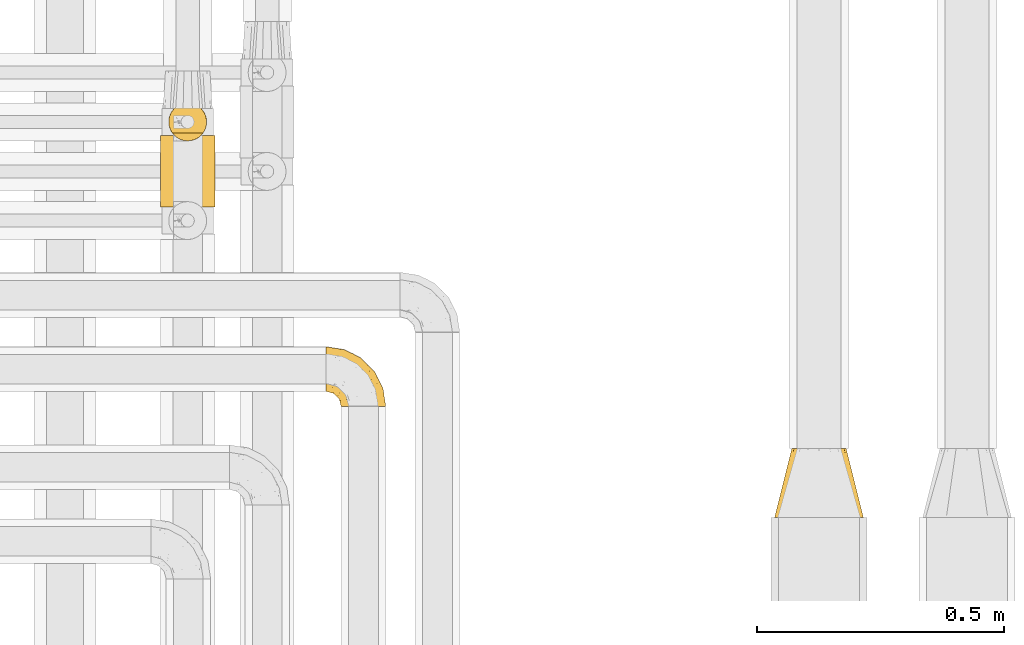
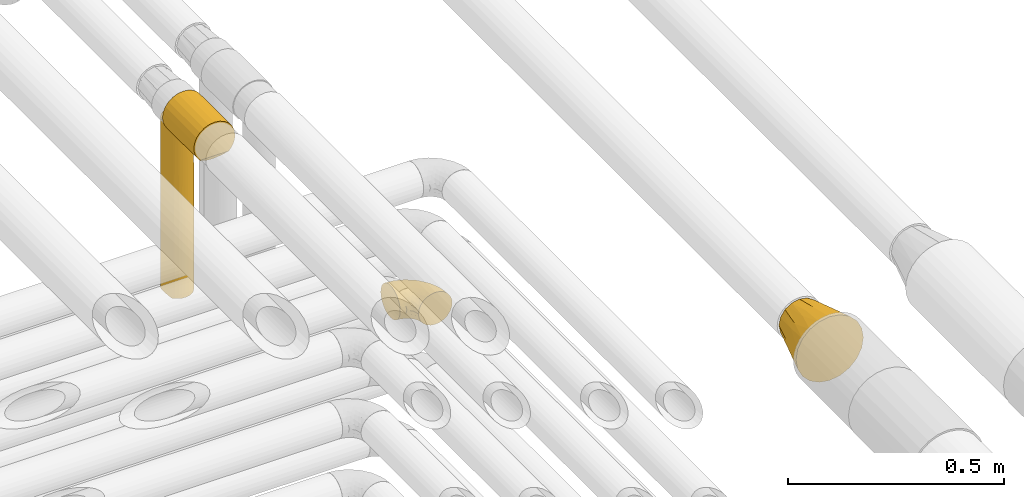
# One storey, part 342 of 827: 4 coverings.
"""IFC2X3 building model written with IfcOpenShell, lengths in millimetres."""

from ifc_helpers import new_model, entity, si_unit, converted_unit, derived_unit, direction, frame, origin, place, context, subcontext, project, spatial, faceted_brep, element, save


model = new_model("IFC2X3")

# Units and contexts
model_context = context("Model", 3, precision=0.01, world=origin(), true_north=direction((6.12303176911189e-17, 1.0)))
body_context = subcontext(model_context, "Body", "Model", "MODEL_VIEW")
ifc_project = project(units=[si_unit("LENGTHUNIT", "METRE", prefix="MILLI"), si_unit("AREAUNIT", "SQUARE_METRE"), si_unit("VOLUMEUNIT", "CUBIC_METRE"), converted_unit("PLANEANGLEUNIT", "DEGREE", entity("IfcRatioMeasure", 0.0174532925199433), si_unit("PLANEANGLEUNIT", "RADIAN"), dimensions=[0, 0, 0, 0, 0, 0, 0]), si_unit("MASSUNIT", "GRAM", prefix="KILO"), derived_unit("MASSDENSITYUNIT", [(si_unit("MASSUNIT", "GRAM", prefix="KILO"), 1), (si_unit("LENGTHUNIT", "METRE"), -3)]), derived_unit("MOMENTOFINERTIAUNIT", [(si_unit("LENGTHUNIT", "METRE"), 4)]), si_unit("TIMEUNIT", "SECOND"), si_unit("FREQUENCYUNIT", "HERTZ"), si_unit("THERMODYNAMICTEMPERATUREUNIT", "DEGREE_CELSIUS"), derived_unit("THERMALTRANSMITTANCEUNIT", [(si_unit("MASSUNIT", "GRAM", prefix="KILO"), 1), (si_unit("THERMODYNAMICTEMPERATUREUNIT", "KELVIN"), -1), (si_unit("TIMEUNIT", "SECOND"), -3)]), derived_unit("VOLUMETRICFLOWRATEUNIT", [(si_unit("LENGTHUNIT", "METRE"), 3), (si_unit("TIMEUNIT", "SECOND"), -1)]), derived_unit("MASSFLOWRATEUNIT", [(si_unit("MASSUNIT", "GRAM", prefix="KILO"), 1), (si_unit("TIMEUNIT", "SECOND"), -1)]), derived_unit("ROTATIONALFREQUENCYUNIT", [(si_unit("TIMEUNIT", "SECOND"), -1)]), si_unit("ELECTRICCURRENTUNIT", "AMPERE"), si_unit("ELECTRICVOLTAGEUNIT", "VOLT"), si_unit("POWERUNIT", "WATT"), si_unit("FORCEUNIT", "NEWTON", prefix="KILO"), si_unit("ILLUMINANCEUNIT", "LUX"), si_unit("LUMINOUSFLUXUNIT", "LUMEN"), si_unit("LUMINOUSINTENSITYUNIT", "CANDELA"), derived_unit("USERDEFINED", [(si_unit("MASSUNIT", "GRAM", prefix="KILO"), -1), (si_unit("LENGTHUNIT", "METRE"), -2), (si_unit("TIMEUNIT", "SECOND"), 3), (si_unit("LUMINOUSFLUXUNIT", "LUMEN"), 1)]), derived_unit("LINEARVELOCITYUNIT", [(si_unit("LENGTHUNIT", "METRE"), 1), (si_unit("TIMEUNIT", "SECOND"), -1)]), si_unit("PRESSUREUNIT", "PASCAL"), derived_unit("USERDEFINED", [(si_unit("LENGTHUNIT", "METRE"), -2), (si_unit("MASSUNIT", "GRAM", prefix="KILO"), 1), (si_unit("TIMEUNIT", "SECOND"), -2)]), derived_unit("LINEARFORCEUNIT", [(si_unit("MASSUNIT", "GRAM", prefix="KILO"), 1), (si_unit("LENGTHUNIT", "METRE"), 1), (si_unit("TIMEUNIT", "SECOND"), -2), (si_unit("LENGTHUNIT", "METRE"), -1)]), derived_unit("PLANARFORCEUNIT", [(si_unit("MASSUNIT", "GRAM", prefix="KILO"), 1), (si_unit("LENGTHUNIT", "METRE"), 1), (si_unit("TIMEUNIT", "SECOND"), -2), (si_unit("LENGTHUNIT", "METRE"), -2)])], contexts=[model_context])

# Site, building, storey
site_placement = place(None, origin())
site = spatial("IfcSite", under=ifc_project, at=site_placement, CompositionType="ELEMENT")
building_placement = place(site_placement, origin())
building = spatial("IfcBuilding", under=site, at=building_placement, CompositionType="ELEMENT")
storey_placement = place(building_placement, frame((0.0, 0.0, 28200.0)))
storey = spatial("IfcBuildingStorey", under=building, at=storey_placement, Name="08", CompositionType="ELEMENT", Elevation=28200.0)

# Coverings
covering_1_placement = place(storey_placement, frame((36428.72, 15450.0, 3027.5)))
element("IfcCovering", 1, at=covering_1_placement, inside=storey, Name=":ADSK_", ObjectType=":ADSK_", PredefinedType="INSULATION", context=body_context, shape_type="Brep", body=[
    faceted_brep([(77.54, 31.93, 490.0), (78.4, 40.0, 490.0), (77.09, 49.93, 490.0), (73.25, 59.2, 490.0), (67.15, 67.15, 490.0), (59.2, 73.25, 490.0), (49.93, 77.09, 490.0), (40.0, 78.4, 490.0), (30.06, 77.09, 490.0), (20.8, 73.25, 490.0), (12.84, 67.15, 490.0), (6.74, 59.2, 490.0), (2.9, 49.93, 490.0), (1.6, 40.0, 490.0), (2.45, 31.93, 490.0), (4.98, 24.24, 490.0), (9.06, 17.25, 490.0), (70.93, 17.25, 490.0), (75.01, 24.24, 490.0), (78.4, 40.0, 1.6), (77.09, 30.06, 1.6), (73.25, 20.8, 1.6), (67.15, 12.84, 1.6), (59.2, 6.74, 1.6), (49.93, 2.9, 1.6), (40.0, 1.6, 1.6), (31.79, 2.48, 1.6), (23.98, 5.09, 1.6), (16.91, 9.31, 1.6), (10.9, 14.94, 1.6), (10.9, 65.05, 1.6), (16.91, 70.68, 1.6), (23.98, 74.9, 1.6), (31.79, 77.51, 1.6), (40.0, 78.4, 1.6), (49.93, 77.09, 1.6), (59.2, 73.25, 1.6), (67.15, 67.15, 1.6), (73.25, 59.2, 1.6), (77.09, 49.93, 1.6), (78.4, 40.0, 273.62), (76.48, 28.02, 255.92), (47.46, 2.33, 209.58), (54.76, 4.55, 223.03), (40.0, 1.6, 251.27), (45.97, 2.06, 468.31), (62.33, 8.76, 227.69), (69.27, 15.14, 243.58), (57.33, 5.73, 473.55), (51.79, 3.45, 470.29), (73.48, 21.19, 294.68), (67.02, 12.71, 483.52), (40.0, 1.6, 467.64), (62.45, 8.84, 477.99), (77.65, 47.54, 282.85), (75.47, 54.69, 245.8), (47.38, 77.68, 280.14), (54.69, 75.47, 245.8), (70.46, 63.37, 245.8), (63.37, 70.46, 245.8), (40.0, 78.4, 217.97), (27.82, 76.41, 235.98), (16.62, 70.46, 267.16), (1.6, 40.0, 227.27), (2.97, 50.18, 239.69), (2.2, 46.78, 10.29), (5.35, 56.56, 302.34), (8.89, 62.51, 250.15), (4.0, 53.36, 8.5), (1.6, 40.0, 10.9), (6.92, 59.51, 5.57), (1.6, 40.0, 250.45), (2.2, 33.21, 10.29), (4.0, 26.63, 8.5), (2.97, 29.81, 243.75), (6.92, 20.48, 5.57), (8.88, 17.49, 236.9), (5.36, 23.41, 187.01), (14.98, 10.86, 243.74), (32.49, 2.34, 220.4), (12.97, 12.71, 483.52), (25.25, 4.54, 243.03), (34.02, 2.06, 468.31), (28.2, 3.45, 470.29), (17.54, 8.84, 477.99), (22.66, 5.73, 473.55)], [[[0, 1, 2, 3, 4, 5, 6, 7, 8, 9, 10, 11, 12, 13, 14, 15, 16, 17, 18]], [[19, 20, 21, 22, 23, 24, 25, 26, 27, 28, 29, 30, 31, 32, 33, 34, 35, 36, 37, 38, 39]], [[40, 41, 20]], [[42, 24, 43]], [[42, 25, 24]], [[44, 42, 45]], [[19, 40, 20]], [[46, 43, 23]], [[24, 23, 43]], [[41, 0, 18]], [[22, 21, 47]], [[43, 46, 48]], [[43, 48, 49]], [[49, 45, 42]], [[47, 46, 22]], [[21, 41, 50]], [[51, 47, 17]], [[21, 20, 41]], [[25, 42, 44]], [[40, 1, 0]], [[45, 52, 44]], [[51, 53, 46]], [[47, 50, 17]], [[41, 18, 50]], [[21, 50, 47]], [[17, 50, 18]], [[40, 0, 41]], [[51, 46, 47]], [[42, 43, 49]], [[46, 53, 48]], [[22, 46, 23]], [[54, 39, 55]], [[35, 56, 57]], [[54, 1, 40, 19]], [[55, 39, 38]], [[54, 19, 39]], [[2, 55, 3]], [[55, 2, 54]], [[58, 4, 3]], [[58, 55, 38]], [[59, 58, 37]], [[7, 56, 60]], [[57, 36, 35]], [[35, 34, 60]], [[56, 6, 57]], [[7, 6, 56]], [[59, 5, 4]], [[57, 59, 36]], [[35, 60, 56]], [[57, 5, 59]], [[58, 59, 4]], [[37, 58, 38]], [[5, 57, 6]], [[36, 59, 37]], [[1, 54, 2]], [[55, 58, 3]], [[60, 33, 61]], [[32, 31, 62]], [[62, 61, 32]], [[63, 64, 65]], [[33, 60, 34]], [[61, 33, 32]], [[61, 9, 8]], [[62, 10, 9]], [[12, 11, 66]], [[67, 62, 30]], [[66, 68, 64]], [[67, 10, 62]], [[65, 64, 68]], [[11, 10, 67]], [[65, 69, 63]], [[66, 70, 68]], [[60, 61, 8]], [[66, 11, 67]], [[62, 31, 30]], [[13, 12, 64]], [[64, 63, 71, 13]], [[61, 62, 9]], [[70, 66, 67]], [[70, 67, 30]], [[12, 66, 64]], [[7, 60, 8]], [[72, 73, 74]], [[75, 76, 77]], [[75, 29, 76]], [[78, 76, 29]], [[44, 79, 25]], [[74, 73, 77]], [[14, 71, 74]], [[71, 72, 74]], [[15, 14, 74]], [[15, 77, 76]], [[75, 77, 73]], [[74, 77, 15]], [[15, 76, 16]], [[76, 78, 80]], [[81, 78, 28]], [[44, 52, 82]], [[71, 14, 13]], [[82, 79, 44]], [[81, 26, 79]], [[72, 71, 63, 69]], [[83, 79, 82]], [[83, 81, 79]], [[84, 80, 78]], [[80, 16, 76]], [[83, 85, 81]], [[81, 85, 84]], [[28, 27, 81]], [[81, 84, 78]], [[26, 81, 27]], [[78, 29, 28]], [[25, 79, 26]], [[48, 53, 51, 17, 16, 80, 84, 85, 83, 82, 52, 45, 49]], [[65, 68, 70, 30, 29, 75, 73, 72, 69]]]),
])
covering_2_placement = place(storey_placement, frame((36412.12, 15315.9, 3493.4)))
element("IfcCovering", 2, at=covering_2_placement, inside=storey, Name=":ADSK_", ObjectType=":ADSK_", PredefinedType="INSULATION", context=body_context, shape_type="Brep", body=[
    faceted_brep([(1.6, 1.6, 56.6), (2.68, 1.6, 45.71), (5.89, 1.6, 35.29), (11.1, 1.6, 25.69), (18.1, 1.6, 17.31), (95.09, 1.6, 17.31), (102.09, 1.6, 25.69), (107.3, 1.6, 35.29), (110.51, 1.6, 45.71), (111.6, 1.6, 56.6), (109.72, 1.6, 70.83), (104.23, 1.6, 84.1), (95.49, 1.6, 95.49), (84.1, 1.6, 104.23), (70.83, 1.6, 109.72), (56.6, 1.6, 111.6), (42.36, 1.6, 109.72), (29.1, 1.6, 104.23), (17.7, 1.6, 95.49), (8.96, 1.6, 84.1), (3.47, 1.6, 70.83), (18.1, 146.6, 17.31), (11.1, 146.6, 25.69), (5.89, 146.6, 35.29), (2.68, 146.6, 45.71), (1.6, 146.6, 56.6), (3.47, 146.6, 70.83), (8.96, 146.6, 84.1), (17.7, 146.6, 95.49), (29.1, 146.6, 104.23), (42.36, 146.6, 109.72), (56.6, 146.6, 111.6), (70.83, 146.6, 109.72), (84.1, 146.6, 104.23), (95.49, 146.6, 95.49), (104.23, 146.6, 84.1), (109.72, 146.6, 70.83), (111.6, 146.6, 56.6), (110.51, 146.6, 45.71), (107.3, 146.6, 35.29), (102.09, 146.6, 25.69), (95.09, 146.6, 17.31), (26.39, 141.92, 10.63), (26.39, 6.27, 10.63), (35.81, 138.45, 5.68), (46.0, 136.32, 2.62), (46.0, 11.87, 2.62), (35.81, 9.74, 5.68), (56.6, 135.6, 1.6), (56.6, 12.6, 1.6), (67.19, 136.32, 2.62), (67.19, 11.87, 2.62), (77.38, 138.45, 5.68), (86.8, 141.92, 10.63), (86.8, 6.27, 10.63), (77.38, 9.74, 5.68)], [[[0, 1, 2, 3, 4, 5, 6, 7, 8, 9, 10, 11, 12, 13, 14, 15, 16, 17, 18, 19, 20]], [[21, 22, 23, 24, 25, 26, 27, 28, 29, 30, 31, 32, 33, 34, 35, 36, 37, 38, 39, 40, 41]], [[25, 24, 1, 0]], [[23, 22, 3, 2]], [[24, 23, 2, 1]], [[22, 21, 4, 3]], [[21, 42, 43, 4]], [[44, 45, 46, 47]], [[42, 44, 47, 43]], [[45, 48, 49, 46]], [[48, 50, 51, 49]], [[52, 53, 54, 55]], [[50, 52, 55, 51]], [[5, 54, 53, 41]], [[7, 6, 40, 39]], [[8, 7, 39, 38]], [[9, 8, 38, 37]], [[41, 40, 6, 5]], [[10, 9, 37, 36]], [[11, 10, 36, 35]], [[35, 34, 12, 11]], [[14, 13, 33, 32]], [[15, 14, 32, 31]], [[34, 33, 13, 12]], [[16, 15, 31, 30]], [[17, 16, 30, 29]], [[29, 28, 18, 17]], [[20, 19, 27, 26]], [[0, 20, 26, 25]], [[28, 27, 19, 18]], [[43, 47, 46, 49, 51, 55, 54, 5, 4]], [[53, 52, 50, 48, 45, 44, 42, 21, 41]]]),
])
covering_3_placement = place(storey_placement, frame((36747.44, 14911.41, 3153.25)))
element("IfcCovering", 3, at=covering_3_placement, inside=storey, Name=":ADSK_", ObjectType=":ADSK_", PredefinedType="INSULATION", context=body_context, shape_type="Brep", body=[
    faceted_brep([(1.6, 87.65, 90.76), (1.6, 97.19, 87.42), (1.6, 105.75, 82.04), (1.6, 112.9, 74.89), (1.6, 118.28, 66.33), (1.6, 121.61, 56.79), (1.6, 122.75, 46.75), (1.6, 121.61, 36.69), (1.6, 118.27, 27.15), (1.6, 112.89, 18.59), (1.6, 105.74, 11.44), (1.6, 97.18, 6.06), (1.6, 87.64, 2.73), (1.6, 77.6, 1.6), (1.6, 67.54, 2.73), (1.6, 58.0, 6.07), (1.6, 49.44, 11.45), (1.6, 42.29, 18.6), (1.6, 36.91, 27.16), (1.6, 33.58, 36.7), (1.6, 32.45, 46.75), (1.6, 33.58, 56.8), (1.6, 36.92, 66.34), (1.6, 42.3, 74.9), (1.6, 49.45, 82.05), (1.6, 58.01, 87.43), (1.6, 67.55, 90.76), (1.6, 77.6, 91.9), (33.98, 1.6, 35.06), (38.49, 1.6, 24.17), (45.67, 1.6, 14.82), (55.02, 1.6, 7.64), (65.91, 1.6, 3.13), (77.6, 1.6, 1.6), (89.28, 1.6, 3.13), (100.17, 1.6, 7.64), (109.52, 1.6, 14.82), (116.7, 1.6, 24.17), (121.21, 1.6, 35.06), (122.75, 1.6, 46.75), (121.21, 1.6, 58.43), (116.7, 1.6, 69.32), (109.52, 1.6, 78.67), (100.17, 1.6, 85.85), (89.28, 1.6, 90.36), (77.6, 1.6, 91.9), (65.91, 1.6, 90.36), (55.02, 1.6, 85.85), (45.67, 1.6, 78.67), (38.49, 1.6, 69.32), (33.98, 1.6, 58.43), (32.45, 1.6, 46.75), (72.81, 99.61, 46.75), (77.17, 95.26, 55.2), (86.21, 86.21, 46.75), (116.82, 39.03, 46.75), (118.49, 30.75, 54.53), (119.23, 23.8, 46.75), (105.14, 60.8, 59.63), (85.37, 85.37, 62.07), (89.33, 73.64, 71.86), (116.14, 31.01, 62.65), (105.06, 49.14, 71.33), (112.15, 23.88, 72.93), (22.95, 82.74, 91.2), (89.91, 43.48, 86.31), (103.39, 29.47, 80.89), (93.6, 56.38, 79.49), (51.41, 72.18, 90.68), (67.71, 72.24, 86.84), (43.53, 87.6, 87.38), (30.91, 107.24, 76.87), (23.58, 101.1, 83.73), (50.07, 95.16, 81.03), (30.68, 71.81, 91.9), (43.01, 63.57, 91.9), (55.34, 55.34, 91.9), (83.48, 23.66, 91.03), (94.96, 20.55, 87.58), (57.29, 107.97, 56.52), (39.03, 116.82, 46.75), (30.66, 117.03, 60.4), (71.81, 30.68, 91.9), (73.63, 21.51, 91.9), (75.46, 12.33, 91.9), (51.57, 106.17, 67.87), (73.13, 52.37, 90.35), (23.16, 114.51, 69.57), (23.8, 119.23, 46.75), (75.6, 78.37, 79.91), (12.33, 75.46, 91.9), (21.51, 73.63, 91.9), (50.46, 101.51, 74.99), (99.61, 72.81, 46.75), (63.57, 43.01, 91.9), (21.26, 92.6, 88.53), (69.54, 91.86, 72.65), (108.21, 55.92, 46.75), (68.42, 99.01, 62.97), (55.92, 108.21, 46.75), (19.36, 32.05, 66.2), (15.76, 30.22, 56.6), (26.13, 23.37, 59.89), (62.78, 28.43, 90.95), (63.65, 16.44, 90.22), (24.34, 37.1, 76.64), (28.46, 28.88, 71.58), (33.53, 33.93, 79.99), (39.46, 50.17, 89.54), (51.05, 40.57, 89.97), (10.94, 47.62, 81.32), (14.55, 39.9, 74.56), (22.21, 47.92, 84.15), (57.05, 34.27, 90.37), (54.0, 24.65, 87.82), (29.19, 62.6, 90.98), (18.85, 66.18, 90.96), (52.84, 11.74, 85.14), (31.47, 13.89, 58.11), (28.31, 17.02, 46.75), (43.0, 15.86, 78.39), (16.9, 57.71, 88.22), (35.98, 9.11, 66.06), (33.91, 18.55, 68.6), (9.97, 34.74, 63.78), (25.93, 54.95, 88.42), (35.61, 57.35, 90.61), (47.45, 22.03, 83.8), (38.26, 24.8, 77.98), (11.7, 69.07, 91.22), (30.13, 42.31, 83.46), (12.12, 29.63, 46.75), (17.02, 28.31, 46.75), (44.39, 30.23, 84.66), (39.83, 40.13, 86.33), (22.67, 22.67, 46.75), (29.63, 12.12, 46.75), (43.0, 15.86, 15.1), (47.45, 22.03, 9.69), (38.26, 24.8, 15.52), (44.38, 30.23, 8.83), (31.47, 13.88, 35.39), (10.93, 47.61, 12.18), (21.51, 73.63, 1.6), (18.84, 66.17, 2.53), (11.7, 69.07, 2.27), (15.76, 30.22, 36.9), (19.36, 32.04, 27.31), (26.14, 23.36, 33.62), (25.94, 54.93, 5.07), (22.21, 47.91, 9.36), (16.9, 57.69, 5.27), (35.98, 9.1, 27.43), (73.63, 21.51, 1.6), (75.46, 12.33, 1.6), (30.12, 42.29, 10.05), (24.33, 37.09, 16.87), (52.84, 11.74, 8.35), (63.65, 16.44, 3.27), (71.81, 30.68, 1.6), (28.45, 28.86, 21.94), (9.97, 34.74, 29.72), (43.01, 63.57, 1.6), (55.34, 55.34, 1.6), (39.46, 50.17, 3.96), (12.33, 75.46, 1.6), (14.54, 39.89, 18.95), (62.78, 28.43, 2.54), (57.05, 34.27, 3.12), (63.57, 43.01, 1.6), (29.2, 62.59, 2.51), (51.05, 40.57, 3.52), (39.81, 40.13, 7.17), (30.68, 71.81, 1.6), (33.52, 33.92, 13.52), (35.61, 57.34, 2.88), (54.0, 24.65, 5.67), (33.91, 18.54, 24.89), (103.39, 29.47, 12.6), (89.91, 43.48, 7.18), (93.6, 56.4, 14.0), (105.05, 49.17, 22.16), (89.27, 73.69, 21.61), (73.13, 52.37, 3.14), (67.67, 72.26, 6.65), (69.49, 91.88, 20.82), (85.36, 85.36, 31.41), (94.96, 20.55, 5.91), (83.48, 23.66, 2.46), (105.14, 60.8, 33.87), (116.13, 31.02, 30.84), (118.49, 30.75, 38.96), (112.15, 23.9, 20.56), (51.41, 72.17, 2.81), (43.51, 87.59, 6.1), (22.95, 82.74, 2.29), (30.66, 117.03, 33.08), (30.91, 107.23, 16.61), (57.3, 107.97, 36.96), (23.58, 101.08, 9.75), (51.56, 106.17, 25.61), (68.41, 99.01, 30.5), (23.16, 114.5, 23.91), (50.07, 95.15, 12.45), (50.45, 101.5, 18.49), (21.25, 92.59, 4.96), (75.56, 78.38, 13.56), (77.16, 95.27, 38.28)], [[[0, 1, 2, 3, 4, 5, 6, 7, 8, 9, 10, 11, 12, 13, 14, 15, 16, 17, 18, 19, 20, 21, 22, 23, 24, 25, 26, 27]], [[28, 29, 30, 31, 32, 33, 34, 35, 36, 37, 38, 39, 40, 41, 42, 43, 44, 45, 46, 47, 48, 49, 50, 51]], [[52, 53, 54]], [[55, 56, 57]], [[58, 59, 60]], [[61, 62, 63]], [[27, 64, 0]], [[65, 66, 67]], [[41, 40, 61]], [[68, 69, 70]], [[66, 43, 42]], [[63, 42, 41]], [[71, 72, 73]], [[72, 2, 1]], [[68, 74, 75, 76]], [[45, 44, 77]], [[43, 78, 44]], [[79, 80, 81]], [[77, 82, 83, 84, 45]], [[79, 81, 85]], [[71, 2, 72]], [[65, 86, 77]], [[4, 81, 5]], [[66, 65, 78]], [[4, 3, 87]], [[81, 88, 5]], [[63, 66, 42]], [[68, 70, 64]], [[67, 60, 89]], [[71, 3, 2]], [[64, 27, 90, 91, 74]], [[92, 71, 73]], [[40, 57, 56]], [[59, 93, 54]], [[86, 76, 94, 82]], [[1, 0, 95]], [[58, 62, 61]], [[60, 96, 89]], [[85, 81, 87]], [[56, 97, 58]], [[65, 67, 69]], [[87, 81, 4]], [[67, 89, 69]], [[61, 63, 41]], [[95, 72, 1]], [[73, 72, 70]], [[69, 73, 70]], [[73, 89, 96]], [[3, 71, 87]], [[85, 87, 71]], [[58, 61, 56]], [[59, 58, 93]], [[76, 86, 68]], [[69, 89, 73]], [[68, 86, 69]], [[65, 69, 86]], [[68, 64, 74]], [[95, 64, 70]], [[98, 79, 85]], [[79, 52, 99, 80]], [[66, 62, 67]], [[62, 58, 60]], [[62, 60, 67]], [[59, 98, 96]], [[59, 96, 60]], [[96, 85, 92]], [[88, 81, 80]], [[88, 6, 5]], [[66, 63, 62]], [[64, 95, 0]], [[72, 95, 70]], [[77, 44, 78]], [[86, 82, 77]], [[40, 39, 57]], [[96, 98, 85]], [[40, 56, 61]], [[66, 78, 43]], [[77, 78, 65]], [[79, 98, 53]], [[96, 92, 73]], [[85, 71, 92]], [[97, 56, 55]], [[97, 93, 58]], [[53, 98, 59]], [[54, 53, 59]], [[79, 53, 52]], [[100, 101, 102]], [[46, 45, 84, 83]], [[103, 104, 82]], [[82, 104, 83]], [[105, 106, 107]], [[108, 109, 76]], [[110, 111, 112]], [[103, 113, 114]], [[115, 74, 116]], [[48, 47, 117]], [[118, 102, 119]], [[49, 48, 120]], [[74, 91, 116]], [[116, 121, 115]], [[49, 122, 50]], [[123, 106, 102]], [[124, 111, 22]], [[125, 126, 115]], [[23, 22, 111]], [[24, 110, 121]], [[120, 127, 128]], [[90, 26, 129]], [[27, 26, 90]], [[121, 125, 115]], [[24, 121, 25]], [[130, 105, 107]], [[129, 25, 116]], [[21, 20, 131]], [[120, 123, 122]], [[112, 105, 130]], [[50, 118, 51]], [[21, 124, 22]], [[101, 131, 132]], [[117, 120, 48]], [[24, 23, 110]], [[127, 114, 133]], [[75, 108, 76]], [[107, 134, 130]], [[133, 114, 113]], [[129, 116, 91]], [[25, 121, 116]], [[121, 112, 125]], [[75, 74, 115]], [[101, 135, 102]], [[131, 101, 21]], [[101, 100, 124]], [[128, 127, 133]], [[119, 136, 51, 118]], [[104, 47, 46]], [[83, 104, 46]], [[117, 104, 114]], [[101, 124, 21]], [[111, 124, 100]], [[102, 118, 123]], [[133, 134, 107]], [[111, 110, 23]], [[114, 104, 103]], [[94, 76, 109]], [[121, 110, 112]], [[122, 118, 50]], [[134, 109, 108]], [[133, 107, 128]], [[112, 108, 125]], [[126, 125, 108]], [[108, 75, 126]], [[75, 115, 126]], [[109, 134, 133]], [[130, 108, 112]], [[108, 130, 134]], [[105, 112, 111]], [[111, 100, 105]], [[106, 105, 100]], [[102, 106, 100]], [[128, 106, 123]], [[90, 129, 91]], [[25, 129, 26]], [[104, 117, 47]], [[117, 114, 127]], [[82, 94, 103]], [[113, 94, 109]], [[94, 113, 103]], [[133, 113, 109]], [[106, 128, 107]], [[123, 120, 128]], [[120, 122, 49]], [[118, 122, 123]], [[135, 101, 132]], [[135, 119, 102]], [[117, 127, 120]], [[30, 29, 137]], [[138, 139, 140]], [[51, 136, 119, 141]], [[142, 17, 16]], [[143, 144, 145]], [[146, 147, 148]], [[149, 150, 151]], [[152, 29, 28]], [[33, 32, 153, 154]], [[150, 155, 156]], [[157, 31, 30]], [[153, 158, 159]], [[29, 152, 137]], [[148, 141, 119]], [[156, 160, 147]], [[148, 135, 146]], [[137, 138, 157]], [[19, 161, 146]], [[162, 163, 164]], [[14, 13, 165]], [[153, 32, 158]], [[147, 161, 166]], [[18, 17, 166]], [[167, 168, 169]], [[166, 150, 156]], [[151, 150, 142]], [[151, 170, 149]], [[151, 16, 15]], [[171, 140, 172]], [[165, 143, 145]], [[173, 170, 144]], [[142, 166, 17]], [[19, 131, 20]], [[144, 170, 151]], [[18, 161, 19]], [[173, 144, 143]], [[140, 139, 174]], [[171, 164, 163]], [[164, 172, 155]], [[151, 15, 144]], [[145, 15, 14]], [[173, 162, 170]], [[149, 175, 164]], [[19, 146, 131]], [[132, 131, 146]], [[160, 148, 147]], [[159, 158, 167]], [[135, 132, 146]], [[158, 32, 31]], [[157, 158, 31]], [[167, 158, 176]], [[166, 161, 18]], [[146, 161, 147]], [[148, 177, 141]], [[171, 168, 140]], [[171, 163, 169]], [[151, 142, 16]], [[166, 142, 150]], [[152, 141, 177]], [[51, 141, 28]], [[138, 140, 176]], [[172, 140, 174]], [[175, 149, 170]], [[164, 150, 149]], [[170, 162, 175]], [[162, 164, 175]], [[155, 172, 174]], [[171, 172, 164]], [[155, 174, 156]], [[164, 155, 150]], [[160, 156, 174]], [[147, 166, 156]], [[139, 160, 174]], [[148, 160, 177]], [[15, 145, 144]], [[165, 145, 14]], [[137, 157, 30]], [[158, 157, 176]], [[168, 167, 176]], [[169, 159, 167]], [[140, 168, 176]], [[169, 168, 171]], [[137, 177, 139]], [[160, 139, 177]], [[141, 152, 28]], [[137, 152, 177]], [[148, 119, 135]], [[157, 138, 176]], [[139, 138, 137]], [[178, 179, 180]], [[181, 180, 182]], [[179, 183, 184]], [[185, 186, 182]], [[187, 188, 179]], [[188, 33, 154, 153, 159]], [[181, 189, 190]], [[35, 34, 187]], [[191, 38, 190]], [[192, 178, 181]], [[179, 184, 180]], [[192, 190, 37]], [[37, 190, 38]], [[36, 35, 178]], [[54, 93, 186]], [[35, 187, 178]], [[193, 194, 184]], [[195, 173, 143, 165, 13]], [[195, 193, 173]], [[193, 163, 162, 173]], [[13, 12, 195]], [[8, 7, 196]], [[9, 197, 10]], [[198, 80, 99, 52]], [[196, 7, 88]], [[197, 199, 10]], [[182, 189, 181]], [[200, 198, 201]], [[200, 196, 198]], [[9, 8, 202]], [[194, 199, 203]], [[192, 37, 36]], [[80, 196, 88]], [[183, 159, 169, 163]], [[188, 34, 33]], [[202, 200, 197]], [[185, 203, 204]], [[202, 8, 196]], [[10, 199, 11]], [[12, 11, 205]], [[38, 191, 57]], [[189, 97, 191]], [[203, 199, 197]], [[205, 199, 194]], [[204, 203, 197]], [[184, 203, 206]], [[200, 202, 196]], [[197, 9, 202]], [[207, 54, 186]], [[97, 55, 191]], [[194, 203, 184]], [[183, 163, 193]], [[184, 206, 180]], [[183, 193, 184]], [[205, 195, 12]], [[193, 195, 194]], [[80, 198, 196]], [[207, 186, 201]], [[182, 180, 206]], [[181, 178, 180]], [[185, 182, 206]], [[182, 186, 189]], [[203, 185, 206]], [[185, 200, 201]], [[7, 6, 88]], [[178, 192, 36]], [[190, 192, 181]], [[199, 205, 11]], [[195, 205, 194]], [[159, 183, 188]], [[179, 188, 183]], [[57, 191, 55]], [[57, 39, 38]], [[189, 191, 190]], [[188, 187, 34]], [[178, 187, 179]], [[186, 93, 189]], [[197, 200, 204]], [[185, 204, 200]], [[189, 93, 97]], [[207, 198, 52]], [[185, 201, 186]], [[198, 207, 201]], [[54, 207, 52]]]),
])
covering_4_placement = place(storey_placement, frame((37656.7, 14687.72, 2808.36)))
element("IfcCovering", 4, at=covering_4_placement, inside=storey, Name=":ADSK_", ObjectType=":ADSK_", PredefinedType="INSULATION", context=body_context, shape_type="Brep", body=[
    faceted_brep([(121.56, 140.0, 136.45), (130.49, 140.0, 130.49), (136.45, 140.0, 121.56), (142.41, 140.0, 112.64), (144.5, 140.0, 102.12), (146.6, 140.0, 91.59), (144.5, 140.0, 81.07), (142.41, 140.0, 70.55), (136.45, 140.0, 61.63), (130.49, 140.0, 52.7), (121.56, 140.01, 46.74), (112.64, 140.01, 40.78), (102.12, 140.01, 38.69), (91.6, 140.01, 36.59), (81.07, 140.01, 38.69), (70.55, 140.01, 40.78), (61.63, 140.01, 46.74), (52.7, 140.0, 52.7), (46.74, 140.0, 61.63), (40.78, 140.0, 70.55), (38.69, 140.0, 81.07), (36.6, 140.0, 91.59), (38.69, 140.0, 102.12), (40.78, 140.0, 112.64), (46.74, 140.0, 121.56), (52.7, 140.0, 130.49), (61.63, 140.0, 136.45), (70.55, 140.0, 142.41), (81.07, 140.0, 144.5), (91.6, 140.0, 146.59), (102.12, 140.0, 144.5), (112.64, 140.0, 142.41), (119.41, 0.0, 177.19), (91.6, 0.0, 181.6), (63.78, 0.0, 177.19), (38.69, 0.0, 164.41), (18.78, 0.0, 144.5), (6.0, 0.0, 119.41), (1.6, 0.0, 91.6), (6.0, 0.0, 63.78), (18.78, 0.01, 38.69), (38.69, 0.01, 18.78), (63.78, 0.01, 6.0), (91.6, 0.01, 1.6), (119.41, 0.01, 6.0), (144.5, 0.01, 18.78), (164.41, 0.01, 38.69), (177.19, 0.0, 63.78), (181.6, 0.0, 91.6), (177.19, 0.0, 119.41), (164.41, 0.0, 144.5), (144.5, 0.0, 164.41), (159.94, 74.31, 70.86), (146.21, 66.32, 42.52), (162.14, 77.82, 91.59), (164.1, 70.0, 91.59), (153.91, 72.47, 55.77), (111.37, 75.26, 23.21), (126.28, 65.7, 26.71), (91.6, 70.01, 19.09), (91.6, 77.82, 21.05), (70.86, 74.31, 23.25), (42.52, 66.32, 36.98), (55.77, 72.47, 29.28), (23.21, 75.26, 71.82), (26.71, 65.7, 56.91), (19.1, 70.0, 91.59), (21.05, 77.82, 91.59), (23.25, 74.31, 112.33), (36.98, 66.32, 140.67), (29.28, 72.47, 127.42), (71.82, 75.26, 159.98), (56.91, 65.7, 156.48), (91.6, 70.0, 164.09), (91.6, 77.82, 162.14), (112.33, 74.31, 159.94), (140.67, 66.32, 146.21), (127.42, 72.47, 153.91), (159.98, 75.26, 111.37), (156.48, 65.7, 126.28)], [[[0, 1, 2, 3, 4, 5, 6, 7, 8, 9, 10, 11, 12, 13, 14, 15, 16, 17, 18, 19, 20, 21, 22, 23, 24, 25, 26, 27, 28, 29, 30, 31]], [[32, 33, 34, 35, 36, 37, 38, 39, 40, 41, 42, 43, 44, 45, 46, 47, 48, 49, 50, 51]], [[47, 52, 48]], [[9, 53, 10]], [[7, 6, 52]], [[52, 54, 55, 48]], [[56, 52, 47]], [[54, 52, 6]], [[56, 7, 52]], [[57, 58, 44]], [[45, 44, 58]], [[10, 53, 58]], [[46, 45, 53]], [[12, 57, 59]], [[45, 58, 53]], [[58, 57, 11]], [[53, 56, 46]], [[56, 47, 46]], [[53, 8, 56]], [[43, 57, 44]], [[10, 58, 11]], [[6, 5, 54]], [[57, 43, 59]], [[8, 53, 9]], [[12, 11, 57]], [[8, 7, 56]], [[12, 59, 60, 13]], [[42, 61, 43]], [[17, 62, 18]], [[15, 14, 61]], [[61, 60, 59, 43]], [[63, 61, 42]], [[60, 61, 14]], [[63, 15, 61]], [[64, 65, 39]], [[40, 39, 65]], [[18, 62, 65]], [[41, 40, 62]], [[20, 64, 66]], [[40, 65, 62]], [[65, 64, 19]], [[62, 63, 41]], [[63, 42, 41]], [[62, 16, 63]], [[38, 64, 39]], [[18, 65, 19]], [[14, 13, 60]], [[64, 38, 66]], [[16, 62, 17]], [[20, 19, 64]], [[16, 15, 63]], [[20, 66, 67, 21]], [[37, 68, 38]], [[25, 69, 26]], [[23, 22, 68]], [[68, 67, 66, 38]], [[70, 68, 37]], [[67, 68, 22]], [[70, 23, 68]], [[71, 72, 34]], [[35, 34, 72]], [[26, 69, 72]], [[36, 35, 69]], [[28, 71, 73]], [[35, 72, 69]], [[72, 71, 27]], [[69, 70, 36]], [[70, 37, 36]], [[69, 24, 70]], [[33, 71, 34]], [[26, 72, 27]], [[22, 21, 67]], [[71, 33, 73]], [[24, 69, 25]], [[28, 27, 71]], [[24, 23, 70]], [[28, 73, 74, 29]], [[32, 75, 33]], [[1, 76, 2]], [[31, 30, 75]], [[75, 74, 73, 33]], [[77, 75, 32]], [[74, 75, 30]], [[77, 31, 75]], [[78, 79, 49]], [[50, 49, 79]], [[2, 76, 79]], [[51, 50, 76]], [[4, 78, 55]], [[50, 79, 76]], [[79, 78, 3]], [[76, 77, 51]], [[77, 32, 51]], [[76, 0, 77]], [[48, 78, 49]], [[2, 79, 3]], [[30, 29, 74]], [[78, 48, 55]], [[0, 76, 1]], [[4, 3, 78]], [[0, 31, 77]], [[4, 55, 54, 5]]]),
])

save(model, "model.ifc")
